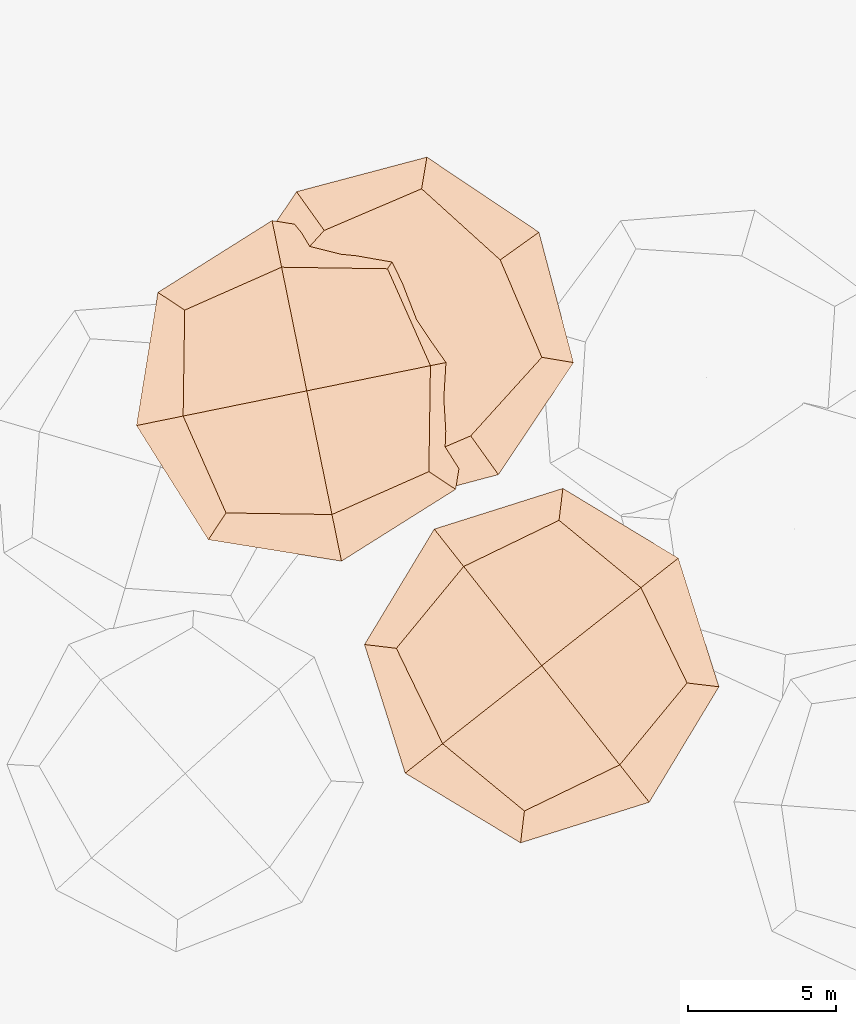
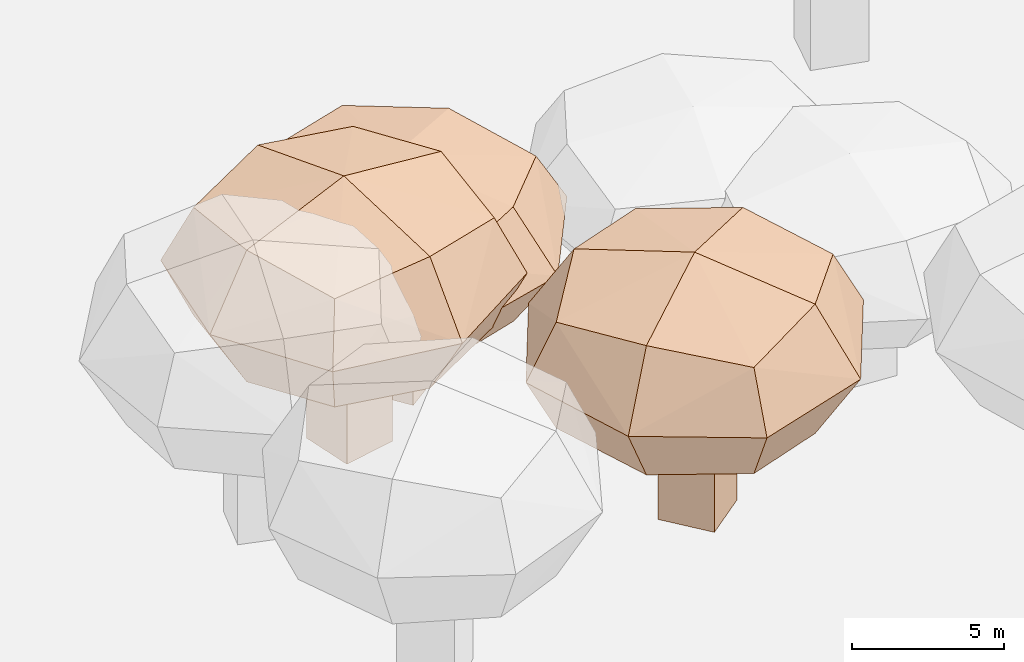
# Not in any storey, part 18 of 92: 3 geographic elements.
"""IFC4 model written with IfcOpenShell, lengths in metres."""

from ifc_helpers import new_model, si_unit, origin_with_axes, place, context, subcontext, project, spatial, triangles, material, element, save


model = new_model("IFC4")

# Units and contexts
model_context = context("Model", 3, precision=1e-05, world=origin_with_axes())
body_context = subcontext(model_context, "Body", "Model", "MODEL_VIEW")
ifc_project = project(units=[si_unit("VOLUMEUNIT", "CUBIC_METRE"), si_unit("LENGTHUNIT", "METRE"), si_unit("AREAUNIT", "SQUARE_METRE")], contexts=[model_context])

# Site
site_placement = place(None, origin_with_axes())
site = spatial("IfcSite", under=ifc_project, at=site_placement)

# Geographic elements
ifc_material = material(Name="tree")
geographic_element_1_placement = place(site_placement, origin_with_axes())
element("IfcGeographicElement", 1, at=geographic_element_1_placement, inside=site, material=ifc_material, Name="cw_instances_tree_216", context=body_context, shape_type="Tessellation", body=[
    triangles([(196.1152792904209, -611.7145894422515, 6.074334077433429), (196.1152792904209, -611.7145894422515, 6.074334077433429), (196.1152792904209, -611.7145894422515, 6.074334077433429), (196.1152792904209, -611.7145894422515, 0.0), (196.1152792904209, -611.7145894422515, 0.0), (196.1152792904209, -611.7145894422515, 0.0), (197.35215514446773, -613.2862567485463, 6.074334077433429), (197.35215514446773, -613.2862567485463, 6.074334077433429), (197.35215514446773, -613.2862567485463, 6.074334077433429), (197.35215514446773, -613.2862567485463, 0.0), (197.35215514446773, -613.2862567485463, 0.0), (197.35215514446773, -613.2862567485463, 0.0), (194.5436119841261, -612.9514652962984, 6.074334077433429), (194.5436119841261, -612.9514652962984, 6.074334077433429), (194.5436119841261, -612.9514652962984, 6.074334077433429), (194.5436119841261, -612.9514652962984, 0.0), (194.5436119841261, -612.9514652962984, 0.0), (194.5436119841261, -612.9514652962984, 0.0), (195.78048783817295, -614.5231326025931, 6.074334077433429), (195.78048783817295, -614.5231326025931, 6.074334077433429), (195.78048783817295, -614.5231326025931, 6.074334077433429), (195.78048783817295, -614.5231326025931, 0.0), (195.78048783817295, -614.5231326025931, 0.0), (195.78048783817295, -614.5231326025931, 0.0), (196.33829415745274, -608.357745915002, 9.048116802974235), (196.33829415745274, -608.357745915002, 9.048116802974235), (196.33829415745274, -608.357745915002, 9.048116802974235), (196.33829415745274, -608.357745915002, 9.048116802974235), (196.33829415745274, -608.357745915002, 9.048116802974235), (196.33829415745274, -608.357745915002, 9.048116802974235), (196.33829404920263, -608.3577453893768, 4.796083118852199), (196.33829404920263, -608.3577453893768, 4.796083118852199), (196.33829404920263, -608.3577453893768, 4.796083118852199), (196.33829404920263, -608.3577453893768, 4.796083118852199), (196.33829404920263, -608.3577453893768, 4.796083118852199), (196.33829404920263, -608.3577453893768, 4.796083118852199), (200.66735880242547, -613.8585800262665, 9.048116802974235), (200.66735880242547, -613.8585800262665, 9.048116802974235), (200.66735880242547, -613.8585800262665, 9.048116802974235), (200.66735880242547, -613.8585800262665, 9.048116802974235), (200.66735880242547, -613.8585800262665, 9.048116802974235), (200.66735880242547, -613.8585800262665, 9.048116802974235), (200.66735880242547, -613.8585800262665, 4.796083118852199), (200.66735880242547, -613.8585800262665, 4.796083118852199), (200.66735880242547, -613.8585800262665, 4.796083118852199), (200.66735880242547, -613.8585800262665, 4.796083118852199), (200.66735880242547, -613.8585800262665, 4.796083118852199), (200.66735880242547, -613.8585800262665, 4.796083118852199), (190.83745884651273, -612.686810587875, 9.048116802974235), (190.83745884651273, -612.686810587875, 9.048116802974235), (190.83745884651273, -612.686810587875, 9.048116802974235), (190.83745884651273, -612.686810587875, 9.048116802974235), (190.83745884651273, -612.686810587875, 9.048116802974235), (190.83745884651273, -612.686810587875, 9.048116802974235), (190.8374592237129, -612.6868102910248, 4.796083118852199), (190.8374592237129, -612.6868102910248, 4.796083118852199), (190.8374592237129, -612.6868102910248, 4.796083118852199), (190.8374592237129, -612.6868102910248, 4.796083118852199), (190.8374592237129, -612.6868102910248, 4.796083118852199), (190.8374592237129, -612.6868102910248, 4.796083118852199), (195.1665237481607, -618.1876454133647, 9.048116802974235), (195.1665237481607, -618.1876454133647, 9.048116802974235), (195.1665237481607, -618.1876454133647, 9.048116802974235), (195.1665237481607, -618.1876454133647, 9.048116802974235), (195.1665237481607, -618.1876454133647, 9.048116802974235), (195.1665237481607, -618.1876454133647, 9.048116802974235), (195.1665235997356, -618.1876452247647, 4.796083118852199), (195.1665235997356, -618.1876452247647, 4.796083118852199), (195.1665235997356, -618.1876452247647, 4.796083118852199), (195.1665235997356, -618.1876452247647, 4.796083118852199), (195.1665235997356, -618.1876452247647, 4.796083118852199), (195.1665235997356, -618.1876452247647, 4.796083118852199), (192.39927660335727, -615.9115543920111, 4.330197399685171), (192.39927660335727, -615.9115543920111, 4.330197399685171), (192.39927660335727, -615.9115543920111, 4.330197399685171), (192.39927660335727, -615.9115543920111, 4.330197399685171), (193.11355023799882, -609.9195634444662, 4.330197399685171), (193.11355023799882, -609.9195634444662, 4.330197399685171), (193.11355023799882, -609.9195634444662, 4.330197399685171), (193.11355023799882, -609.9195634444662, 4.330197399685171), (196.4666821457538, -607.2807047779246, 6.922100325373283), (196.4666821457538, -607.2807047779246, 6.922100325373283), (196.4666821457538, -607.2807047779246, 6.922100325373283), (196.4666821457538, -607.2807047779246, 6.922100325373283), (195.03813528226772, -619.2646863154828, 6.922100325373283), (195.03813528226772, -619.2646863154828, 6.922100325373283), (195.03813528226772, -619.2646863154828, 6.922100325373283), (195.03813528226772, -619.2646863154828, 6.922100325373283), (201.74440018213545, -613.9869687271189, 6.922100325373283), (201.74440018213545, -613.9869687271189, 6.922100325373283), (201.74440018213545, -613.9869687271189, 6.922100325373283), (201.74440018213545, -613.9869687271189, 6.922100325373283), (189.76041828309383, -612.5584221481142, 6.922100325373283), (189.76041828309383, -612.5584221481142, 6.922100325373283), (189.76041828309383, -612.5584221481142, 6.922100325373283), (189.76041828309383, -612.5584221481142, 6.922100325373283), (198.39126790503866, -616.6258276843264, 9.514002157681194), (198.39126790503866, -616.6258276843264, 9.514002157681194), (198.39126790503866, -616.6258276843264, 9.514002157681194), (198.39126790503866, -616.6258276843264, 9.514002157681194), (199.1055411507154, -610.6338363557221, 9.514003585149789), (199.1055411507154, -610.6338363557221, 9.514003585149789), (199.1055411507154, -610.6338363557221, 9.514003585149789), (199.1055411507154, -610.6338363557221, 9.514003585149789), (198.39126757508117, -616.6258273459065, 4.330197399685171), (198.39126757508117, -616.6258273459065, 4.330197399685171), (198.39126757508117, -616.6258273459065, 4.330197399685171), (198.39126757508117, -616.6258273459065, 4.330197399685171), (192.39927657861975, -615.9115543605777, 9.514002157681194), (192.39927657861975, -615.9115543605777, 9.514002157681194), (192.39927657861975, -615.9115543605777, 9.514002157681194), (192.39927657861975, -615.9115543605777, 9.514002157681194), (193.11355026157383, -609.9195634259131, 9.514003585149789), (193.11355026157383, -609.9195634259131, 9.514003585149789), (193.11355026157383, -609.9195634259131, 9.514003585149789), (193.11355026157383, -609.9195634259131, 9.514003585149789), (199.10554081847985, -610.6338366935379, 4.330197399685171), (199.10554081847985, -610.6338366935379, 4.330197399685171), (199.10554081847985, -610.6338366935379, 4.330197399685171), (199.10554081847985, -610.6338366935379, 4.330197399685171), (195.75240876746128, -613.2726953073962, 10.491709383506818), (195.75240876746128, -613.2726953073962, 10.491709383506818), (195.75240876746128, -613.2726953073962, 10.491709383506818), (195.75240876746128, -613.2726953073962, 10.491709383506818), (195.75240876746128, -613.2726953073962, 10.491709383506818), (195.75240876746128, -613.2726953073962, 10.491709383506818), (195.75240876746128, -613.2726953073962, 10.491709383506818), (195.75240876746128, -613.2726953073962, 10.491709383506818), (199.38668557972426, -617.8906801028554, 6.922100325373283), (199.38668557972426, -617.8906801028554, 6.922100325373283), (199.38668557972426, -617.8906801028554, 6.922100325373283), (199.38668557972426, -617.8906801028554, 6.922100325373283), (199.38668557972426, -617.8906801028554, 6.922100325373283), (199.38668557972426, -617.8906801028554, 6.922100325373283), (199.38668557972426, -617.8906801028554, 6.922100325373283), (199.38668557972426, -617.8906801028554, 6.922100325373283), (191.1344241662751, -616.9069720431216, 6.922100325373283), (191.1344241662751, -616.9069720431216, 6.922100325373283), (191.1344241662751, -616.9069720431216, 6.922100325373283), (191.1344241662751, -616.9069720431216, 6.922100325373283), (191.1344241662751, -616.9069720431216, 6.922100325373283), (191.1344241662751, -616.9069720431216, 6.922100325373283), (191.1344241662751, -616.9069720431216, 6.922100325373283), (191.1344241662751, -616.9069720431216, 6.922100325373283), (195.75240887747796, -613.272695220815, 3.3524919657882086), (195.75240887747796, -613.272695220815, 3.3524919657882086), (195.75240887747796, -613.272695220815, 3.3524919657882086), (195.75240887747796, -613.272695220815, 3.3524919657882086), (195.75240887747796, -613.272695220815, 3.3524919657882086), (195.75240887747796, -613.272695220815, 3.3524919657882086), (195.75240887747796, -613.272695220815, 3.3524919657882086), (195.75240887747796, -613.272695220815, 3.3524919657882086), (200.37039315661195, -609.6384189166939, 6.922100325373283), (200.37039315661195, -609.6384189166939, 6.922100325373283), (200.37039315661195, -609.6384189166939, 6.922100325373283), (200.37039315661195, -609.6384189166939, 6.922100325373283), (200.37039315661195, -609.6384189166939, 6.922100325373283), (200.37039315661195, -609.6384189166939, 6.922100325373283), (200.37039315661195, -609.6384189166939, 6.922100325373283), (200.37039315661195, -609.6384189166939, 6.922100325373283), (192.11813222717134, -608.654710679659, 6.922100325373283), (192.11813222717134, -608.654710679659, 6.922100325373283), (192.11813222717134, -608.654710679659, 6.922100325373283), (192.11813222717134, -608.654710679659, 6.922100325373283), (192.11813222717134, -608.654710679659, 6.922100325373283), (192.11813222717134, -608.654710679659, 6.922100325373283), (192.11813222717134, -608.654710679659, 6.922100325373283), (192.11813222717134, -608.654710679659, 6.922100325373283)], [[15, 8, 2], [7, 24, 11], [19, 16, 22], [4, 23, 17], [3, 12, 6], [14, 5, 18], [26, 127, 101], [54, 123, 114], [124, 66, 98], [128, 38, 102], [45, 133, 108], [40, 135, 89], [130, 63, 88], [131, 70, 105], [68, 141, 73], [61, 140, 86], [137, 49, 93], [142, 56, 74], [59, 145, 75], [31, 149, 79], [150, 43, 107], [146, 71, 76], [35, 154, 120], [30, 157, 83], [158, 42, 91], [153, 47, 119], [58, 164, 77], [51, 162, 96], [167, 28, 81], [165, 33, 80], [15, 21, 8], [7, 20, 24], [19, 13, 16], [4, 10, 23], [3, 9, 12], [14, 1, 5], [25, 115, 126], [53, 111, 121], [122, 112, 65], [125, 99, 37], [46, 90, 136], [39, 100, 134], [132, 97, 64], [129, 87, 69], [67, 85, 138], [62, 110, 144], [143, 109, 50], [139, 94, 55], [60, 78, 147], [32, 117, 151], [152, 118, 44], [148, 106, 72], [36, 84, 160], [29, 104, 156], [155, 103, 41], [159, 92, 48], [57, 95, 161], [52, 113, 163], [166, 116, 27], [168, 82, 34]], closed=True),
])
geographic_element_2_placement = place(site_placement, origin_with_axes())
element("IfcGeographicElement", 2, at=geographic_element_2_placement, inside=site, material=ifc_material, Name="cw_instances_tree_221", context=body_context, shape_type="Tessellation", body=[
    triangles([(191.3101026099377, -600.4904560223588, 5.385394515376934), (191.3101026099377, -600.4904560223588, 5.385394515376934), (191.3101026099377, -600.4904560223588, 5.385394515376934), (191.3101026099377, -600.4904560223588, 0.0), (191.3101026099377, -600.4904560223588, 0.0), (191.3101026099377, -600.4904560223588, 0.0), (192.4716038904266, -602.1186190287629, 5.385394515376934), (192.4716038904266, -602.1186190287629, 5.385394515376934), (192.4716038904266, -602.1186190287629, 5.385394515376934), (192.4716038904266, -602.1186190287629, 0.0), (192.4716038904266, -602.1186190287629, 0.0), (192.4716038904266, -602.1186190287629, 0.0), (189.68193960353364, -601.6519573028477, 5.385394515376934), (189.68193960353364, -601.6519573028477, 5.385394515376934), (189.68193960353364, -601.6519573028477, 5.385394515376934), (189.68193960353364, -601.6519573028477, 0.0), (189.68193960353364, -601.6519573028477, 0.0), (189.68193960353364, -601.6519573028477, 0.0), (190.84344088402253, -603.2801203092517, 5.385394515376934), (190.84344088402253, -603.2801203092517, 5.385394515376934), (190.84344088402253, -603.2801203092517, 5.385394515376934), (190.84344088402253, -603.2801203092517, 0.0), (190.84344088402253, -603.2801203092517, 0.0), (190.84344088402253, -603.2801203092517, 0.0), (191.69092871210844, -597.1478364542268, 8.021896389639487), (191.69092871210844, -597.1478364542268, 8.021896389639487), (191.69092871210844, -597.1478364542268, 8.021896389639487), (191.69092871210844, -597.1478364542268, 8.021896389639487), (191.69092871210844, -597.1478364542268, 8.021896389639487), (191.69092871210844, -597.1478364542268, 8.021896389639487), (191.6909286287277, -597.1478359240874, 4.252120379666688), (191.6909286287277, -597.1478359240874, 4.252120379666688), (191.6909286287277, -597.1478359240874, 4.252120379666688), (191.6909286287277, -597.1478359240874, 4.252120379666688), (191.6909286287277, -597.1478359240874, 4.252120379666688), (191.6909286287277, -597.1478359240874, 4.252120379666688), (195.7561824193455, -602.8464054777447, 8.021896389639487), (195.7561824193455, -602.8464054777447, 8.021896389639487), (195.7561824193455, -602.8464054777447, 8.021896389639487), (195.7561824193455, -602.8464054777447, 8.021896389639487), (195.7561824193455, -602.8464054777447, 8.021896389639487), (195.7561824193455, -602.8464054777447, 8.021896389639487), (195.7561824193455, -602.8464054777447, 4.252120379666688), (195.7561824193455, -602.8464054777447, 4.252120379666688), (195.7561824193455, -602.8464054777447, 4.252120379666688), (195.7561824193455, -602.8464054777447, 4.252120379666688), (195.7561824193455, -602.8464054777447, 4.252120379666688), (195.7561824193455, -602.8464054777447, 4.252120379666688), (185.9923584889318, -601.2130901328458, 8.021896389639487), (185.9923584889318, -601.2130901328458, 8.021896389639487), (185.9923584889318, -601.2130901328458, 8.021896389639487), (185.9923584889318, -601.2130901328458, 8.021896389639487), (185.9923584889318, -601.2130901328458, 8.021896389639487), (185.9923584889318, -601.2130901328458, 8.021896389639487), (185.99235887969093, -601.2130898540854, 4.252120379666688), (185.99235887969093, -601.2130898540854, 4.252120379666688), (185.99235887969093, -601.2130898540854, 4.252120379666688), (185.99235887969093, -601.2130898540854, 4.252120379666688), (185.99235887969093, -601.2130898540854, 4.252120379666688), (185.99235887969093, -601.2130898540854, 4.252120379666688), (190.05761241892975, -606.9116598818825, 8.021896389639487), (190.05761241892975, -606.9116598818825, 8.021896389639487), (190.05761241892975, -606.9116598818825, 8.021896389639487), (190.05761241892975, -606.9116598818825, 8.021896389639487), (190.05761241892975, -606.9116598818825, 8.021896389639487), (190.05761241892975, -606.9116598818825, 8.021896389639487), (190.0576122795496, -606.911659686503, 4.252120379666688), (190.0576122795496, -606.911659686503, 4.252120379666688), (190.0576122795496, -606.911659686503, 4.252120379666688), (190.0576122795496, -606.911659686503, 4.252120379666688), (190.0576122795496, -606.911659686503, 4.252120379666688), (190.0576122795496, -606.911659686503, 4.252120379666688), (187.4006053668502, -604.5077961954167, 3.839074543726321), (187.4006053668502, -604.5077961954167, 3.839074543726321), (187.4006053668502, -604.5077961954167, 3.839074543726321), (187.4006053668502, -604.5077961954167, 3.839074543726321), (188.39622254505383, -598.5560830995872, 3.839074543726321), (188.39622254505383, -598.5560830995872, 3.839074543726321), (188.39622254505383, -598.5560830995872, 3.839074543726321), (188.39622254505383, -598.5560830995872, 3.839074543726321), (191.8698872996325, -596.0780351126457, 6.137008707776777), (191.8698872996325, -596.0780351126457, 6.137008707776777), (191.8698872996325, -596.0780351126457, 6.137008707776777), (191.8698872996325, -596.0780351126457, 6.137008707776777), (189.87865336540668, -607.981460966277, 6.137008707776777), (189.87865336540668, -607.981460966277, 6.137008707776777), (189.87865336540668, -607.981460966277, 6.137008707776777), (189.87865336540668, -607.981460966277, 6.137008707776777), (196.8259839697391, -603.0253647884542, 6.137008707776777), (196.8259839697391, -603.0253647884542, 6.137008707776777), (196.8259839697391, -603.0253647884542, 6.137008707776777), (196.8259839697391, -603.0253647884542, 6.137008707776777), (184.9225577416303, -601.0341311213738, 6.137008707776777), (184.9225577416303, -601.0341311213738, 6.137008707776777), (184.9225577416303, -601.0341311213738, 6.137008707776777), (184.9225577416303, -601.0341311213738, 6.137008707776777), (193.35231883254212, -605.5034130483485, 8.434941902456162), (193.35231883254212, -605.5034130483485, 8.434941902456162), (193.35231883254212, -605.5034130483485, 8.434941902456162), (193.35231883254212, -605.5034130483485, 8.434941902456162), (194.34793564015473, -599.5516995535675, 8.434943168023949), (194.34793564015473, -599.5516995535675, 8.434943168023949), (194.34793564015473, -599.5516995535675, 8.434943168023949), (194.34793564015473, -599.5516995535675, 8.434943168023949), (193.35231851888526, -605.5034126947678, 3.839074543726321), (193.35231851888526, -605.5034126947678, 3.839074543726321), (193.35231851888526, -605.5034126947678, 3.839074543726321), (193.35231851888526, -605.5034126947678, 3.839074543726321), (187.40060534362016, -604.5077961628535, 8.434941902456162), (187.40060534362016, -604.5077961628535, 8.434941902456162), (187.40060534362016, -604.5077961628535, 8.434941902456162), (187.40060534362016, -604.5077961628535, 8.434941902456162), (188.39622256947627, -598.5560830821647, 8.434943168023949), (188.39622256947627, -598.5560830821647, 8.434943168023949), (188.39622256947627, -598.5560830821647, 8.434943168023949), (188.39622256947627, -598.5560830821647, 8.434943168023949), (194.34793529238146, -599.5516998753652, 3.839074543726321), (194.34793529238146, -599.5516998753652, 3.839074543726321), (194.34793529238146, -599.5516998753652, 3.839074543726321), (194.34793529238146, -599.5516998753652, 3.839074543726321), (190.87427039717872, -602.0297478029362, 9.301759411089217), (190.87427039717872, -602.0297478029362, 9.301759411089217), (190.87427039717872, -602.0297478029362, 9.301759411089217), (190.87427039717872, -602.0297478029362, 9.301759411089217), (190.87427039717872, -602.0297478029362, 9.301759411089217), (190.87427039717872, -602.0297478029362, 9.301759411089217), (190.87427039717872, -602.0297478029362, 9.301759411089217), (190.87427039717872, -602.0297478029362, 9.301759411089217), (194.28707626998886, -606.813732292225, 6.137008707776777), (194.28707626998886, -606.813732292225, 6.137008707776777), (194.28707626998886, -606.813732292225, 6.137008707776777), (194.28707626998886, -606.813732292225, 6.137008707776777), (194.28707626998886, -606.813732292225, 6.137008707776777), (194.28707626998886, -606.813732292225, 6.137008707776777), (194.28707626998886, -606.813732292225, 6.137008707776777), (194.28707626998886, -606.813732292225, 6.137008707776777), (186.09028610555112, -605.442553608441, 6.137008707776777), (186.09028610555112, -605.442553608441, 6.137008707776777), (186.09028610555112, -605.442553608441, 6.137008707776777), (186.09028610555112, -605.442553608441, 6.137008707776777), (186.09028610555112, -605.442553608441, 6.137008707776777), (186.09028610555112, -605.442553608441, 6.137008707776777), (186.09028610555112, -605.442553608441, 6.137008707776777), (186.09028610555112, -605.442553608441, 6.137008707776777), (190.87427051115012, -602.029747721631, 2.9722586237847435), (190.87427051115012, -602.029747721631, 2.9722586237847435), (190.87427051115012, -602.029747721631, 2.9722586237847435), (190.87427051115012, -602.029747721631, 2.9722586237847435), (190.87427051115012, -602.029747721631, 2.9722586237847435), (190.87427051115012, -602.029747721631, 2.9722586237847435), (190.87427051115012, -602.029747721631, 2.9722586237847435), (190.87427051115012, -602.029747721631, 2.9722586237847435), (195.65825446076042, -598.6169423320879, 6.137008707776777), (195.65825446076042, -598.6169423320879, 6.137008707776777), (195.65825446076042, -598.6169423320879, 6.137008707776777), (195.65825446076042, -598.6169423320879, 6.137008707776777), (195.65825446076042, -598.6169423320879, 6.137008707776777), (195.65825446076042, -598.6169423320879, 6.137008707776777), (195.65825446076042, -598.6169423320879, 6.137008707776777), (195.65825446076042, -598.6169423320879, 6.137008707776777), (187.46146478814273, -597.2457634939891, 6.137008707776777), (187.46146478814273, -597.2457634939891, 6.137008707776777), (187.46146478814273, -597.2457634939891, 6.137008707776777), (187.46146478814273, -597.2457634939891, 6.137008707776777), (187.46146478814273, -597.2457634939891, 6.137008707776777), (187.46146478814273, -597.2457634939891, 6.137008707776777), (187.46146478814273, -597.2457634939891, 6.137008707776777), (187.46146478814273, -597.2457634939891, 6.137008707776777)], [[15, 8, 2], [7, 24, 11], [19, 16, 22], [4, 23, 17], [3, 12, 6], [14, 5, 18], [26, 127, 101], [54, 123, 114], [124, 66, 98], [128, 38, 102], [45, 133, 108], [40, 135, 89], [130, 63, 88], [131, 70, 105], [68, 141, 73], [61, 140, 86], [137, 49, 93], [142, 56, 74], [59, 145, 75], [31, 149, 79], [150, 43, 107], [146, 71, 76], [35, 154, 120], [30, 157, 83], [158, 42, 91], [153, 47, 119], [58, 164, 77], [51, 162, 96], [167, 28, 81], [165, 33, 80], [15, 21, 8], [7, 20, 24], [19, 13, 16], [4, 10, 23], [3, 9, 12], [14, 1, 5], [25, 115, 126], [53, 111, 121], [122, 112, 65], [125, 99, 37], [46, 90, 136], [39, 100, 134], [132, 97, 64], [129, 87, 69], [67, 85, 138], [62, 110, 144], [143, 109, 50], [139, 94, 55], [60, 78, 147], [32, 117, 151], [152, 118, 44], [148, 106, 72], [36, 84, 160], [29, 104, 156], [155, 103, 41], [159, 92, 48], [57, 95, 161], [52, 113, 163], [166, 116, 27], [168, 82, 34]], closed=True),
])
geographic_element_3_placement = place(site_placement, origin_with_axes())
element("IfcGeographicElement", 3, at=geographic_element_3_placement, inside=site, material=ifc_material, Name="cw_instances_tree_222", context=body_context, shape_type="Tessellation", body=[
    triangles([(188.83196609024498, -602.7518217365097, 6.193267156636398), (188.83196609024498, -602.7518217365097, 6.193267156636398), (188.83196609024498, -602.7518217365097, 6.193267156636398), (188.83196609024498, -602.7518217365097, 0.0), (188.83196609024498, -602.7518217365097, 0.0), (188.83196609024498, -602.7518217365097, 0.0), (189.23127102652464, -604.7115552816282, 6.193267156636398), (189.23127102652464, -604.7115552816282, 6.193267156636398), (189.23127102652464, -604.7115552816282, 6.193267156636398), (189.23127102652464, -604.7115552816282, 0.0), (189.23127102652464, -604.7115552816282, 0.0), (189.23127102652464, -604.7115552816282, 0.0), (186.87223254512648, -603.1511266727894, 6.193267156636398), (186.87223254512648, -603.1511266727894, 6.193267156636398), (186.87223254512648, -603.1511266727894, 6.193267156636398), (186.87223254512648, -603.1511266727894, 0.0), (186.87223254512648, -603.1511266727894, 0.0), (186.87223254512648, -603.1511266727894, 0.0), (187.27153748140614, -605.1108602179079, 6.193267156636398), (187.27153748140614, -605.1108602179079, 6.193267156636398), (187.27153748140614, -605.1108602179079, 6.193267156636398), (187.27153748140614, -605.1108602179079, 0.0), (187.27153748140614, -605.1108602179079, 0.0), (187.27153748140614, -605.1108602179079, 0.0), (190.5387619404775, -599.852687034054, 9.225275381782685), (190.5387619404775, -599.852687034054, 9.225275381782685), (190.5387619404775, -599.852687034054, 9.225275381782685), (190.5387619404775, -599.852687034054, 9.225275381782685), (190.5387619404775, -599.852687034054, 9.225275381782685), (190.5387619404775, -599.852687034054, 9.225275381782685), (190.53876207981236, -599.8526865158013, 4.8899885455486976), (190.53876207981236, -599.8526865158013, 4.8899885455486976), (190.53876207981236, -599.8526865158013, 4.8899885455486976), (190.53876207981236, -599.8526865158013, 4.8899885455486976), (190.53876207981236, -599.8526865158013, 4.8899885455486976), (190.53876207981236, -599.8526865158013, 4.8899885455486976), (191.93632911920474, -606.7117527576746, 9.225275381782685), (191.93632911920474, -606.7117527576746, 9.225275381782685), (191.93632911920474, -606.7117527576746, 9.225275381782685), (191.93632911920474, -606.7117527576746, 9.225275381782685), (191.93632911920474, -606.7117527576746, 9.225275381782685), (191.93632911920474, -606.7117527576746, 9.225275381782685), (191.93632911920474, -606.7117527576746, 4.8899885455486976), (191.93632911920474, -606.7117527576746, 4.8899885455486976), (191.93632911920474, -606.7117527576746, 4.8899885455486976), (191.93632911920474, -606.7117527576746, 4.8899885455486976), (191.93632911920474, -606.7117527576746, 4.8899885455486976), (191.93632911920474, -606.7117527576746, 4.8899885455486976), (183.67969513243503, -601.2502536989435, 9.225275381782685), (183.67969513243503, -601.2502536989435, 9.225275381782685), (183.67969513243503, -601.2502536989435, 9.225275381782685), (183.67969513243503, -601.2502536989435, 9.225275381782685), (183.67969513243503, -601.2502536989435, 9.225275381782685), (183.67969513243503, -601.2502536989435, 9.225275381782685), (183.67969560277106, -601.2502536031103, 4.8899885455486976), (183.67969560277106, -601.2502536031103, 4.8899885455486976), (183.67969560277106, -601.2502536031103, 4.8899885455486976), (183.67969560277106, -601.2502536031103, 4.8899885455486976), (183.67969560277106, -601.2502536031103, 4.8899885455486976), (183.67969560277106, -601.2502536031103, 4.8899885455486976), (185.077262219744, -608.1093201759849, 9.225275381782685), (185.077262219744, -608.1093201759849, 9.225275381782685), (185.077262219744, -608.1093201759849, 9.225275381782685), (185.077262219744, -608.1093201759849, 9.225275381782685), (185.077262219744, -608.1093201759849, 9.225275381782685), (185.077262219744, -608.1093201759849, 9.225275381782685), (185.0772621718274, -608.1093199408168, 4.8899885455486976), (185.0772621718274, -608.1093199408168, 4.8899885455486976), (185.0772621718274, -608.1093199408168, 4.8899885455486976), (185.0772621718274, -608.1093199408168, 4.8899885455486976), (185.0772621718274, -608.1093199408168, 4.8899885455486976), (185.0772621718274, -608.1093199408168, 4.8899885455486976), (183.62694543959, -604.8329153879415, 4.414980966696167), (183.62694543959, -604.8329153879415, 4.414980966696167), (183.62694543959, -604.8329153879415, 4.414980966696167), (183.62694543959, -604.8329153879415, 4.414980966696167), (186.95610025055973, -599.7999370862597, 4.414980966696167), (186.95610025055973, -599.7999370862597, 4.414980966696167), (186.95610025055973, -599.7999370862597, 4.414980966696167), (186.95610025055973, -599.7999370862597, 4.414980966696167), (191.13716646890998, -598.9480251597338, 7.057632335261744), (191.13716646890998, -598.9480251597338, 7.057632335261744), (191.13716646890998, -598.9480251597338, 7.057632335261744), (191.13716646890998, -598.9480251597338, 7.057632335261744), (184.478857370109, -609.0139816258891, 7.057632335261744), (184.478857370109, -609.0139816258891, 7.057632335261744), (184.478857370109, -609.0139816258891, 7.057632335261744), (184.478857370109, -609.0139816258891, 7.057632335261744), (192.84099089031156, -607.3101580317256, 7.057632335261744), (192.84099089031156, -607.3101580317256, 7.057632335261744), (192.84099089031156, -607.3101580317256, 7.057632335261744), (192.84099089031156, -607.3101580317256, 7.057632335261744), (182.7750339734175, -600.6518490247648, 7.057632335261744), (182.7750339734175, -600.6518490247648, 7.057632335261744), (182.7750339734175, -600.6518490247648, 7.057632335261744), (182.7750339734175, -600.6518490247648, 7.057632335261744), (188.65992421142394, -608.1620700520882, 9.700282589039164), (188.65992421142394, -608.1620700520882, 9.700282589039164), (188.65992421142394, -608.1620700520882, 9.700282589039164), (188.65992421142394, -608.1620700520882, 9.700282589039164), (191.98907884599066, -603.129091235254, 9.700284044457034), (191.98907884599066, -603.129091235254, 9.700284044457034), (191.98907884599066, -603.129091235254, 9.700284044457034), (191.98907884599066, -603.129091235254, 9.700284044457034), (188.65992406859397, -608.1620696015334, 4.414980966696167), (188.65992406859397, -608.1620696015334, 4.414980966696167), (188.65992406859397, -608.1620696015334, 4.414980966696167), (188.65992406859397, -608.1620696015334, 4.414980966696167), (183.6269454316039, -604.8329153487468, 9.700282589039164), (183.6269454316039, -604.8329153487468, 9.700282589039164), (183.6269454316039, -604.8329153487468, 9.700282589039164), (183.6269454316039, -604.8329153487468, 9.700282589039164), (186.95610027995573, -599.7999370802701, 9.700284044457034), (186.95610027995573, -599.7999370802701, 9.700284044457034), (186.95610027995573, -599.7999370802701, 9.700284044457034), (186.95610027995573, -599.7999370802701, 9.700284044457034), (191.98907839743245, -603.1290913878827, 4.414980966696167), (191.98907839743245, -603.1290913878827, 4.414980966696167), (191.98907839743245, -603.1290913878827, 4.414980966696167), (191.98907839743245, -603.1290913878827, 4.414980966696167), (187.80801207473803, -603.9810032029981, 10.69713293894129), (187.80801207473803, -603.9810032029981, 10.69713293894129), (187.80801207473803, -603.9810032029981, 10.69713293894129), (187.80801207473803, -603.9810032029981, 10.69713293894129), (187.80801207473803, -603.9810032029981, 10.69713293894129), (187.80801207473803, -603.9810032029981, 10.69713293894129), (187.80801207473803, -603.9810032029981, 10.69713293894129), (187.80801207473803, -603.9810032029981, 10.69713293894129), (188.98127836338796, -609.7392319007108, 7.057632335261744), (188.98127836338796, -609.7392319007108, 7.057632335261744), (188.98127836338796, -609.7392319007108, 7.057632335261744), (188.98127836338796, -609.7392319007108, 7.057632335261744), (188.98127836338796, -609.7392319007108, 7.057632335261744), (188.98127836338796, -609.7392319007108, 7.057632335261744), (188.98127836338796, -609.7392319007108, 7.057632335261744), (188.98127836338796, -609.7392319007108, 7.057632335261744), (182.04978358497783, -605.1542695105095, 7.057632335261744), (182.04978358497783, -605.1542695105095, 7.057632335261744), (182.04978358497783, -605.1542695105095, 7.057632335261744), (182.04978358497783, -605.1542695105095, 7.057632335261744), (182.04978358497783, -605.1542695105095, 7.057632335261744), (182.04978358497783, -605.1542695105095, 7.057632335261744), (182.04978358497783, -605.1542695105095, 7.057632335261744), (182.04978358497783, -605.1542695105095, 7.057632335261744), (187.8080122119194, -603.9810031750468, 3.4181324438079614), (187.8080122119194, -603.9810031750468, 3.4181324438079614), (187.8080122119194, -603.9810031750468, 3.4181324438079614), (187.8080122119194, -603.9810031750468, 3.4181324438079614), (187.8080122119194, -603.9810031750468, 3.4181324438079614), (187.8080122119194, -603.9810031750468, 3.4181324438079614), (187.8080122119194, -603.9810031750468, 3.4181324438079614), (187.8080122119194, -603.9810031750468, 3.4181324438079614), (193.5662402201002, -602.807737108536, 7.057632335261744), (193.5662402201002, -602.807737108536, 7.057632335261744), (193.5662402201002, -602.807737108536, 7.057632335261744), (193.5662402201002, -602.807737108536, 7.057632335261744), (193.5662402201002, -602.807737108536, 7.057632335261744), (193.5662402201002, -602.807737108536, 7.057632335261744), (193.5662402201002, -602.807737108536, 7.057632335261744), (193.5662402201002, -602.807737108536, 7.057632335261744), (186.63474595376923, -598.2227747772837, 7.057632335261744), (186.63474595376923, -598.2227747772837, 7.057632335261744), (186.63474595376923, -598.2227747772837, 7.057632335261744), (186.63474595376923, -598.2227747772837, 7.057632335261744), (186.63474595376923, -598.2227747772837, 7.057632335261744), (186.63474595376923, -598.2227747772837, 7.057632335261744), (186.63474595376923, -598.2227747772837, 7.057632335261744), (186.63474595376923, -598.2227747772837, 7.057632335261744)], [[15, 8, 2], [7, 24, 11], [19, 16, 22], [4, 23, 17], [3, 12, 6], [14, 5, 18], [26, 127, 101], [54, 123, 114], [124, 66, 98], [128, 38, 102], [45, 133, 108], [40, 135, 89], [130, 63, 88], [131, 70, 105], [68, 141, 73], [61, 140, 86], [137, 49, 93], [142, 56, 74], [59, 145, 75], [31, 149, 79], [150, 43, 107], [146, 71, 76], [35, 154, 120], [30, 157, 83], [158, 42, 91], [153, 47, 119], [58, 164, 77], [51, 162, 96], [167, 28, 81], [165, 33, 80], [15, 21, 8], [7, 20, 24], [19, 13, 16], [4, 10, 23], [3, 9, 12], [14, 1, 5], [25, 115, 126], [53, 111, 121], [122, 112, 65], [125, 99, 37], [46, 90, 136], [39, 100, 134], [132, 97, 64], [129, 87, 69], [67, 85, 138], [62, 110, 144], [143, 109, 50], [139, 94, 55], [60, 78, 147], [32, 117, 151], [152, 118, 44], [148, 106, 72], [36, 84, 160], [29, 104, 156], [155, 103, 41], [159, 92, 48], [57, 95, 161], [52, 113, 163], [166, 116, 27], [168, 82, 34]], closed=True),
])

save(model, "model.ifc")
